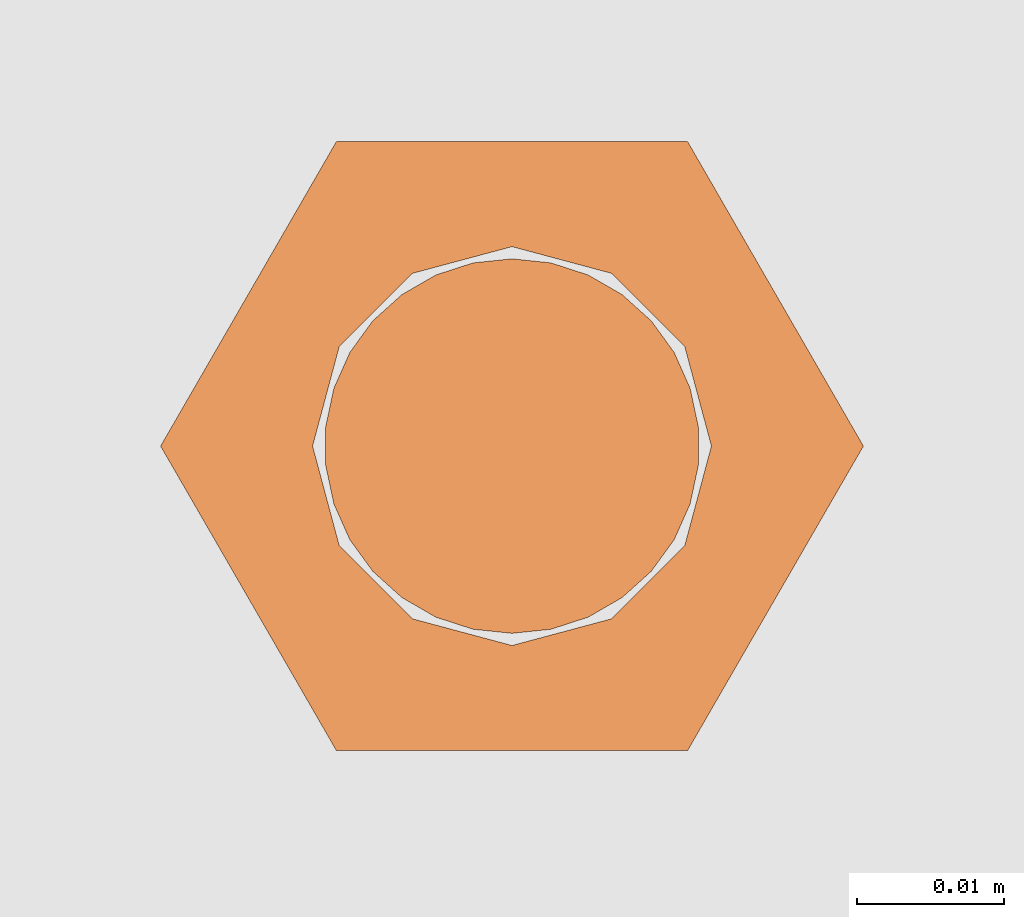
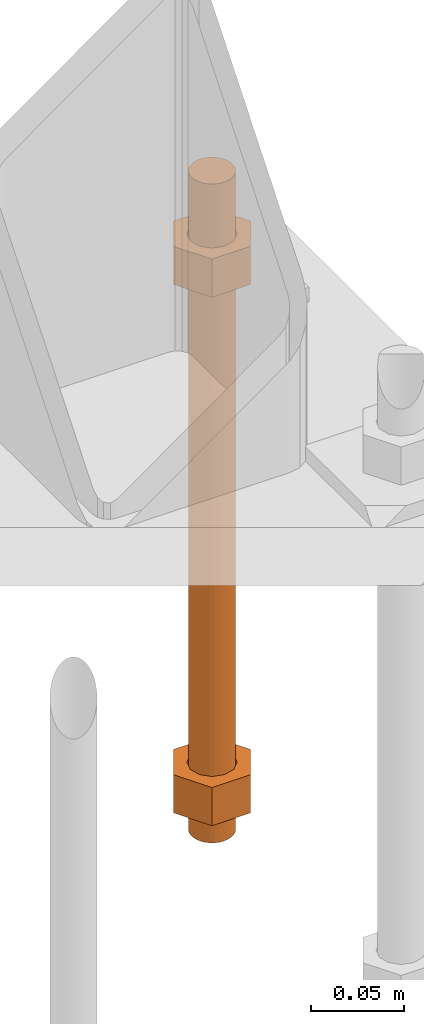
# One storey, part 24 of 89: 1 proxy.
"""IFC4 building model written with IfcOpenShell, lengths in feet."""

from ifc_helpers import new_model, entity, si_unit, converted_unit, derived_unit, direction, frame, origin, place, context, subcontext, project, spatial, faceted_brep, source, transform, mapped, material, constituent, constituent_set, type_object, type_shapes, element, save


model = new_model("IFC4")

# Units and contexts
model_context = context("Model", 3, precision=0.0001, world=origin(), true_north=direction((6.12303176911189e-17, 1.0)))
body_context = subcontext(model_context, "Body", "Model", "MODEL_VIEW")
ifc_project = project(units=[converted_unit("LENGTHUNIT", "FOOT", entity("IfcRatioMeasure", 0.3048), si_unit("LENGTHUNIT", "METRE"), dimensions=[1, 0, 0, 0, 0, 0, 0]), converted_unit("AREAUNIT", "SQUARE FOOT", entity("IfcRatioMeasure", 0.09290304), si_unit("AREAUNIT", "SQUARE_METRE"), dimensions=[2, 0, 0, 0, 0, 0, 0]), converted_unit("VOLUMEUNIT", "CUBIC FOOT", entity("IfcRatioMeasure", 0.028316846592), si_unit("VOLUMEUNIT", "CUBIC_METRE"), dimensions=[3, 0, 0, 0, 0, 0, 0]), si_unit("PLANEANGLEUNIT", "RADIAN"), si_unit("MASSUNIT", "GRAM", prefix="KILO"), derived_unit("MASSDENSITYUNIT", [(si_unit("MASSUNIT", "GRAM", prefix="KILO"), 1), (si_unit("LENGTHUNIT", "METRE"), -3)]), derived_unit("MOMENTOFINERTIAUNIT", [(si_unit("LENGTHUNIT", "METRE"), 4)]), si_unit("TIMEUNIT", "SECOND"), si_unit("FREQUENCYUNIT", "HERTZ"), si_unit("THERMODYNAMICTEMPERATUREUNIT", "DEGREE_CELSIUS"), derived_unit("THERMALTRANSMITTANCEUNIT", [(si_unit("MASSUNIT", "GRAM", prefix="KILO"), 1), (si_unit("THERMODYNAMICTEMPERATUREUNIT", "KELVIN"), -1), (si_unit("TIMEUNIT", "SECOND"), -3)]), derived_unit("VOLUMETRICFLOWRATEUNIT", [(si_unit("LENGTHUNIT", "METRE"), 3), (si_unit("TIMEUNIT", "SECOND"), -1)]), si_unit("ELECTRICCURRENTUNIT", "AMPERE"), si_unit("ELECTRICVOLTAGEUNIT", "VOLT"), si_unit("POWERUNIT", "WATT"), si_unit("FORCEUNIT", "NEWTON"), si_unit("ILLUMINANCEUNIT", "LUX"), si_unit("LUMINOUSFLUXUNIT", "LUMEN"), si_unit("LUMINOUSINTENSITYUNIT", "CANDELA"), derived_unit("USERDEFINED", [(si_unit("MASSUNIT", "GRAM", prefix="KILO"), -1), (si_unit("LENGTHUNIT", "METRE"), -2), (si_unit("TIMEUNIT", "SECOND"), 3), (si_unit("LUMINOUSFLUXUNIT", "LUMEN"), 1)]), derived_unit("LINEARVELOCITYUNIT", [(si_unit("LENGTHUNIT", "METRE"), 1), (si_unit("TIMEUNIT", "SECOND"), -1)]), si_unit("PRESSUREUNIT", "PASCAL"), derived_unit("USERDEFINED", [(si_unit("LENGTHUNIT", "METRE"), -2), (si_unit("MASSUNIT", "GRAM", prefix="KILO"), 1), (si_unit("TIMEUNIT", "SECOND"), -2)]), derived_unit("LINEARFORCEUNIT", [(si_unit("MASSUNIT", "GRAM", prefix="KILO"), 1), (si_unit("LENGTHUNIT", "METRE"), 1), (si_unit("TIMEUNIT", "SECOND"), -2), (si_unit("LENGTHUNIT", "METRE"), -1)]), derived_unit("PLANARFORCEUNIT", [(si_unit("MASSUNIT", "GRAM", prefix="KILO"), 1), (si_unit("LENGTHUNIT", "METRE"), 1), (si_unit("TIMEUNIT", "SECOND"), -2), (si_unit("LENGTHUNIT", "METRE"), -2)])], contexts=[model_context])

# Site, building, storey
site_placement = place(None, origin())
site = spatial("IfcSite", under=ifc_project, at=site_placement, CompositionType="ELEMENT")
building_placement = place(site_placement, frame((-472.238160486, -49.138065117, 0.0)))
building = spatial("IfcBuilding", under=site, at=building_placement, CompositionType="ELEMENT")
storey_placement = place(building_placement, origin())
storey = spatial("IfcBuildingStorey", under=building, at=storey_placement, Name="Level 1", CompositionType="ELEMENT", Elevation=0.0)

# Proxy
ifc_material_1 = material(Name="Color 7721", Category="Materials")
ifc_constituent_1 = constituent(ifc_material_1, Name="Color 7721", Category="Materials")
ifc_material_2 = material(Name="Color 7720", Category="Materials")
ifc_constituent_2 = constituent(ifc_material_2, Name="Color 7720", Category="Materials")
ifc_constituent_set = constituent_set(constituents=[ifc_constituent_1, ifc_constituent_2])
building_element_proxy_type = type_object("IfcBuildingElementProxyType", Name="rb2", PredefinedType="NOTDEFINED", material=ifc_material_1)
shared_shape = source(origin(), body_context, "Body", "Brep", [
    faceted_brep([(0.122545547339314, 0.0677083333333712, 0.0626666666666664), (0.156365697905585, 0.0677083333333712, 0.0626666666666664), (0.117274273429189, 0.135416666666742, 0.0626666666666664), (0.0390914244764531, 0.135416666666742, 0.0626666666666664), (0.0, 0.0677083333333712, 0.0626666666666664), (0.0338201505663278, 0.0677083333333712, 0.0626666666666664), (0.0397636251697122, 0.089889682526632, 0.0626666666666664), (0.0560014997595886, 0.106127557116452, 0.0626666666666664), (0.0781828489528209, 0.112071031719893, 0.0626666666666664), (0.100364198146053, 0.106127557116452, 0.0626666666666664), (0.11660207273593, 0.089889682526632, 0.0626666666666664), (0.117274273429189, 0.0, 0.0626666666666664), (0.0390914244764531, 0.0, 0.0626666666666664), (0.0397636251697122, 0.0455269841401105, 0.0626666666666664), (0.0560014997595886, 0.029289109550291, 0.0626666666666664), (0.0781828489528209, 0.0233456349468497, 0.0626666666666664), (0.100364198146053, 0.029289109550291, 0.0626666666666664), (0.11660207273593, 0.0455269841401105, 0.0626666666666664), (0.0, 0.0677083333333712, 0.144697916666667), (0.0390914244764815, 0.135416666666742, 0.144697916666667), (0.117274273429189, 0.135416666666742, 0.144697916666667), (0.156365697905613, 0.0677083333333712, 0.144697916666667), (0.117274273429217, 0.0, 0.144697916666667), (0.0390914244764531, 0.0, 0.144697916666667), (0.122545547339314, 0.0677083333333712, 0.144697916666666), (0.0338201505663278, 0.0677083333333712, 0.144697916666666), (0.0397636251697122, 0.0455269841401105, 0.144697916666666), (0.0560014997595886, 0.029289109550291, 0.144697916666666), (0.0781828489528209, 0.0233456349468497, 0.144697916666666), (0.100364198146053, 0.029289109550291, 0.144697916666666), (0.11660207273593, 0.0455269841401105, 0.144697916666666), (0.0397636251697122, 0.089889682526632, 0.144697916666666), (0.0560014997595886, 0.106127557116452, 0.144697916666666), (0.0781828489528209, 0.112071031719893, 0.144697916666666), (0.100364198146053, 0.106127557116452, 0.144697916666666), (0.11660207273593, 0.089889682526632, 0.144697916666666)], [[[0, 1, 2, 3, 4, 5, 6, 7, 8, 9, 10]], [[1, 11, 12, 4, 5, 13, 14, 15, 16, 17, 0]], [[4, 18, 19, 3]], [[3, 19, 20, 2]], [[2, 20, 21, 1]], [[1, 21, 22, 11]], [[11, 22, 23, 12]], [[12, 23, 18, 4]], [[24, 21, 22, 23, 18, 25, 26, 27, 28, 29, 30]], [[21, 20, 19, 18, 25, 31, 32, 33, 34, 35, 24]], [[25, 5, 6, 31]], [[31, 6, 7, 32]], [[32, 7, 8, 33]], [[33, 8, 9, 34]], [[34, 9, 10, 35]], [[35, 10, 0, 24]], [[24, 0, 17, 30]], [[30, 17, 16, 29]], [[29, 16, 15, 28]], [[28, 15, 14, 27]], [[27, 14, 13, 26]], [[26, 13, 5, 25]]]),
    faceted_brep([(0.0338201505663278, 0.0677083333333712, 1.28108333333333), (0.0, 0.0677083333333712, 1.28108333333333), (0.0390914244764531, 0.135416666666742, 1.28108333333333), (0.117274273429189, 0.135416666666742, 1.28108333333333), (0.156365697905585, 0.0677083333333712, 1.28108333333333), (0.122545547339314, 0.0677083333333712, 1.28108333333333), (0.11660207273593, 0.089889682526632, 1.28108333333333), (0.100364198146053, 0.106127557116452, 1.28108333333333), (0.0781828489528209, 0.112071031719893, 1.28108333333333), (0.0560014997595886, 0.106127557116452, 1.28108333333333), (0.0397636251697122, 0.089889682526632, 1.28108333333333), (0.0390914244764531, 0.0, 1.28108333333333), (0.117274273429189, 0.0, 1.28108333333333), (0.11660207273593, 0.0455269841401105, 1.28108333333333), (0.100364198146053, 0.029289109550291, 1.28108333333333), (0.0781828489528209, 0.0233456349468497, 1.28108333333333), (0.0560014997595886, 0.029289109550291, 1.28108333333333), (0.0397636251697122, 0.0455269841401105, 1.28108333333333), (0.156365697905557, 0.0677083333333712, 1.19905208333333), (0.11727427342916, 0.135416666666742, 1.19905208333333), (0.0390914244764531, 0.135416666666742, 1.19905208333333), (0.0, 0.0677083333333712, 1.19905208333333), (0.0390914244764247, 0.0, 1.19905208333333), (0.117274273429189, 0.0, 1.19905208333333), (0.0338201505663278, 0.0677083333333712, 1.19905208333333), (0.122545547339314, 0.0677083333333712, 1.19905208333333), (0.11660207273593, 0.0455269841401105, 1.19905208333333), (0.100364198146053, 0.029289109550291, 1.19905208333333), (0.0781828489528209, 0.0233456349468497, 1.19905208333333), (0.0560014997595886, 0.029289109550291, 1.19905208333333), (0.0397636251697122, 0.0455269841401105, 1.19905208333333), (0.11660207273593, 0.089889682526632, 1.19905208333333), (0.100364198146053, 0.106127557116452, 1.19905208333333), (0.0781828489528209, 0.112071031719893, 1.19905208333333), (0.0560014997595886, 0.106127557116452, 1.19905208333333), (0.0397636251697122, 0.089889682526632, 1.19905208333333)], [[[0, 1, 2, 3, 4, 5, 6, 7, 8, 9, 10]], [[1, 11, 12, 4, 5, 13, 14, 15, 16, 17, 0]], [[4, 18, 19, 3]], [[3, 19, 20, 2]], [[2, 20, 21, 1]], [[1, 21, 22, 11]], [[11, 22, 23, 12]], [[12, 23, 18, 4]], [[24, 21, 22, 23, 18, 25, 26, 27, 28, 29, 30]], [[21, 20, 19, 18, 25, 31, 32, 33, 34, 35, 24]], [[25, 5, 6, 31]], [[31, 6, 7, 32]], [[32, 7, 8, 33]], [[33, 8, 9, 34]], [[34, 9, 10, 35]], [[35, 10, 0, 24]], [[24, 0, 17, 30]], [[30, 17, 16, 29]], [[29, 16, 15, 28]], [[28, 15, 14, 27]], [[27, 14, 13, 26]], [[26, 13, 5, 25]]]),
    faceted_brep([(0.0781828489528209, 0.0260416666667425, 0.0), (0.0695198618354027, 0.0269521833027966, 0.0), (0.06123548882465, 0.029643939264929, 0.0), (0.0536917967739612, 0.0339992919010683, 0.0), (0.0472184812246041, 0.0398278914017283, 0.0), (0.0420984571284748, 0.046875, 0.0), (0.038555494107186, 0.0548326252344395, 0.0), (0.0367444366458187, 0.0633529806972319, 0.0), (0.0367444366458187, 0.0720636859695105, 0.0), (0.038555494107186, 0.0805840414323029, 0.0), (0.0420984571284748, 0.0885416666667425, 0.0), (0.0472184812246041, 0.0955887752650142, 0.0), (0.0536917967739612, 0.101417374765674, 0.0), (0.06123548882465, 0.105772727401813, 0.0), (0.0695198618354027, 0.108464483363946, 0.0), (0.0781828489528209, 0.109375, 0.0), (0.0868458360702391, 0.108464483363946, 0.0), (0.0951302090809918, 0.105772727401813, 0.0), (0.102673901131681, 0.101417374765674, 0.0), (0.109147216681038, 0.0955887752650142, 0.0), (0.114267240777167, 0.0885416666667425, 0.0), (0.117810203798456, 0.0805840414323029, 0.0), (0.119621261259823, 0.0720636859695105, 0.0), (0.119621261259823, 0.0633529806972319, 0.0), (0.117810203798456, 0.0548326252344395, 0.0), (0.114267240777167, 0.046875, 0.0), (0.109147216681038, 0.0398278914017283, 0.0), (0.102673901131681, 0.0339992919010683, 0.0), (0.0951302090809918, 0.029643939264929, 0.0), (0.0868458360702391, 0.0269521833027966, 0.0), (0.0868458360702391, 0.0269521833027966, 1.41666666666667), (0.0951302090809918, 0.029643939264929, 1.41666666666667), (0.102673901131681, 0.0339992919010683, 1.41666666666667), (0.109147216681038, 0.0398278914017283, 1.41666666666667), (0.114267240777167, 0.046875, 1.41666666666667), (0.117810203798456, 0.0548326252344395, 1.41666666666667), (0.119621261259823, 0.0633529806972319, 1.41666666666667), (0.119621261259823, 0.0720636859695105, 1.41666666666667), (0.117810203798456, 0.0805840414323029, 1.41666666666667), (0.114267240777167, 0.0885416666667425, 1.41666666666667), (0.109147216681038, 0.0955887752650142, 1.41666666666667), (0.102673901131681, 0.101417374765674, 1.41666666666667), (0.0951302090809918, 0.105772727401813, 1.41666666666667), (0.0868458360702391, 0.108464483363946, 1.41666666666667), (0.0781828489528209, 0.109375, 1.41666666666667), (0.0695198618354027, 0.108464483363946, 1.41666666666667), (0.06123548882465, 0.105772727401813, 1.41666666666667), (0.0536917967739612, 0.101417374765674, 1.41666666666667), (0.0472184812246041, 0.0955887752650142, 1.41666666666667), (0.0420984571284748, 0.0885416666667425, 1.41666666666667), (0.038555494107186, 0.0805840414323029, 1.41666666666667), (0.0367444366458187, 0.0720636859695105, 1.41666666666667), (0.0367444366458187, 0.0633529806972319, 1.41666666666667), (0.038555494107186, 0.0548326252344395, 1.41666666666667), (0.0420984571284748, 0.046875, 1.41666666666667), (0.0472184812246041, 0.0398278914017283, 1.41666666666667), (0.0536917967739612, 0.0339992919010683, 1.41666666666667), (0.06123548882465, 0.029643939264929, 1.41666666666667), (0.0695198618354027, 0.0269521833027966, 1.41666666666667), (0.0781828489528209, 0.0260416666667425, 1.41666666666667), (0.0695198618354027, 0.0269521833027966, 0.25), (0.0781828489528209, 0.0260416666667425, 0.25), (0.06123548882465, 0.029643939264929, 0.25), (0.0536917967739612, 0.0339992919010683, 0.25), (0.047218481224661, 0.0398278914017283, 0.25), (0.0420984571284464, 0.046875, 0.25), (0.038555494107186, 0.0548326252344395, 0.25), (0.0367444366457903, 0.0633529806972319, 0.25), (0.0367444366458187, 0.0720636859695105, 0.25), (0.038555494107186, 0.0805840414323029, 0.25), (0.0420984571285032, 0.0885416666667425, 0.25), (0.0472184812246041, 0.0955887752650142, 0.25), (0.0536917967739896, 0.101417374765674, 0.25), (0.06123548882465, 0.105772727401813, 0.25), (0.0695198618354027, 0.108464483363946, 0.25), (0.0781828489528209, 0.109375, 0.25), (0.0868458360702391, 0.108464483363946, 0.25), (0.0951302090809918, 0.105772727401813, 0.25), (0.102673901131681, 0.101417374765674, 0.25), (0.109147216681095, 0.0955887752650142, 0.25), (0.114267240777167, 0.0885416666667425, 0.25), (0.117810203798371, 0.0805840414323029, 0.25), (0.119621261259823, 0.0720636859695105, 0.25), (0.119621261259823, 0.0633529806972319, 0.25), (0.117810203798456, 0.0548326252344395, 0.25), (0.114267240777224, 0.046875, 0.25), (0.109147216681009, 0.0398278914017283, 0.25), (0.102673901131709, 0.0339992919010683, 0.25), (0.0951302090809918, 0.029643939264929, 0.25), (0.0868458360702391, 0.0269521833027966, 0.25), (0.0695198618354027, 0.0269521833027966, 0.916666666666667), (0.0781828489528209, 0.0260416666667425, 0.916666666666667), (0.06123548882465, 0.029643939264929, 0.916666666666667), (0.0536917967739612, 0.0339992919010683, 0.916666666666667), (0.047218481224661, 0.0398278914017283, 0.916666666666667), (0.0420984571284464, 0.046875, 0.916666666666667), (0.038555494107186, 0.0548326252344395, 0.916666666666667), (0.0367444366457903, 0.0633529806972319, 0.916666666666667), (0.0367444366458187, 0.0720636859695105, 0.916666666666667), (0.038555494107186, 0.0805840414323029, 0.916666666666667), (0.0420984571285032, 0.0885416666667425, 0.916666666666667), (0.0472184812246041, 0.0955887752650142, 0.916666666666667), (0.0536917967739896, 0.101417374765674, 0.916666666666667), (0.06123548882465, 0.105772727401813, 0.916666666666667), (0.0695198618354027, 0.108464483363946, 0.916666666666667), (0.0781828489528209, 0.109375, 0.916666666666667), (0.0868458360702391, 0.108464483363946, 0.916666666666667), (0.0951302090809918, 0.105772727401813, 0.916666666666667), (0.102673901131681, 0.101417374765674, 0.916666666666667), (0.109147216681095, 0.0955887752650142, 0.916666666666667), (0.114267240777167, 0.0885416666667425, 0.916666666666667), (0.117810203798371, 0.0805840414323029, 0.916666666666667), (0.119621261259823, 0.0720636859695105, 0.916666666666667), (0.119621261259823, 0.0633529806972319, 0.916666666666667), (0.117810203798456, 0.0548326252344395, 0.916666666666667), (0.114267240777224, 0.046875, 0.916666666666667), (0.109147216681009, 0.0398278914017283, 0.916666666666667), (0.102673901131709, 0.0339992919010683, 0.916666666666667), (0.0951302090809918, 0.029643939264929, 0.916666666666667), (0.0868458360702391, 0.0269521833027966, 0.916666666666667)], [[[0, 1, 2, 3, 4, 5, 6, 7, 8, 9, 10, 11, 12, 13, 14, 15, 16, 17, 18, 19, 20, 21, 22, 23, 24, 25, 26, 27, 28, 29]], [[30, 31, 32, 33, 34, 35, 36, 37, 38, 39, 40, 41, 42, 43, 44, 45, 46, 47, 48, 49, 50, 51, 52, 53, 54, 55, 56, 57, 58, 59]], [[60, 1, 0, 61]], [[62, 2, 1, 60]], [[63, 3, 2, 62]], [[64, 4, 3, 63]], [[65, 5, 4, 64]], [[66, 6, 5, 65]], [[67, 7, 6, 66]], [[68, 8, 7, 67]], [[69, 9, 8, 68]], [[70, 10, 9, 69]], [[71, 11, 10, 70]], [[72, 12, 11, 71]], [[73, 13, 12, 72]], [[74, 14, 13, 73]], [[75, 15, 14, 74]], [[76, 16, 15, 75]], [[77, 17, 16, 76]], [[78, 18, 17, 77]], [[79, 19, 18, 78]], [[80, 20, 19, 79]], [[81, 21, 20, 80]], [[82, 22, 21, 81]], [[83, 23, 22, 82]], [[84, 24, 23, 83]], [[85, 25, 24, 84]], [[86, 26, 25, 85]], [[87, 27, 26, 86]], [[88, 28, 27, 87]], [[89, 29, 28, 88]], [[61, 0, 29, 89]], [[90, 60, 61, 91]], [[92, 62, 60, 90]], [[93, 63, 62, 92]], [[94, 64, 63, 93]], [[95, 65, 64, 94]], [[96, 66, 65, 95]], [[97, 67, 66, 96]], [[98, 68, 67, 97]], [[99, 69, 68, 98]], [[100, 70, 69, 99]], [[101, 71, 70, 100]], [[102, 72, 71, 101]], [[103, 73, 72, 102]], [[104, 74, 73, 103]], [[105, 75, 74, 104]], [[106, 76, 75, 105]], [[107, 77, 76, 106]], [[108, 78, 77, 107]], [[109, 79, 78, 108]], [[110, 80, 79, 109]], [[111, 81, 80, 110]], [[112, 82, 81, 111]], [[113, 83, 82, 112]], [[114, 84, 83, 113]], [[115, 85, 84, 114]], [[116, 86, 85, 115]], [[117, 87, 86, 116]], [[118, 88, 87, 117]], [[119, 89, 88, 118]], [[91, 61, 89, 119]], [[58, 90, 91, 59]], [[57, 92, 90, 58]], [[56, 93, 92, 57]], [[55, 94, 93, 56]], [[54, 95, 94, 55]], [[53, 96, 95, 54]], [[52, 97, 96, 53]], [[51, 98, 97, 52]], [[50, 99, 98, 51]], [[49, 100, 99, 50]], [[48, 101, 100, 49]], [[47, 102, 101, 48]], [[46, 103, 102, 47]], [[45, 104, 103, 46]], [[44, 105, 104, 45]], [[43, 106, 105, 44]], [[42, 107, 106, 43]], [[41, 108, 107, 42]], [[40, 109, 108, 41]], [[39, 110, 109, 40]], [[38, 111, 110, 39]], [[37, 112, 111, 38]], [[36, 113, 112, 37]], [[35, 114, 113, 36]], [[34, 115, 114, 35]], [[33, 116, 115, 34]], [[32, 117, 116, 33]], [[31, 118, 117, 32]], [[30, 119, 118, 31]], [[59, 91, 119, 30]]]),
])
type_shapes(building_element_proxy_type, [shared_shape])
proxy_placement = place(building_placement, frame((206.984317151047, 997.317708333333, -1.45833333333333)))
element("IfcBuildingElementProxy", 1, at=proxy_placement, inside=storey, type_object=building_element_proxy_type, material=ifc_constituent_set, Name="rb2 486:rb2 486", ObjectType="rb2 486:rb2 486", PredefinedType="NOTDEFINED", context=body_context, shape_type="MappedRepresentation", body=[
    mapped(shared_shape, transform((0.0, 0.0, 0.0), scale=1.0)),
])

save(model, "model.ifc")
